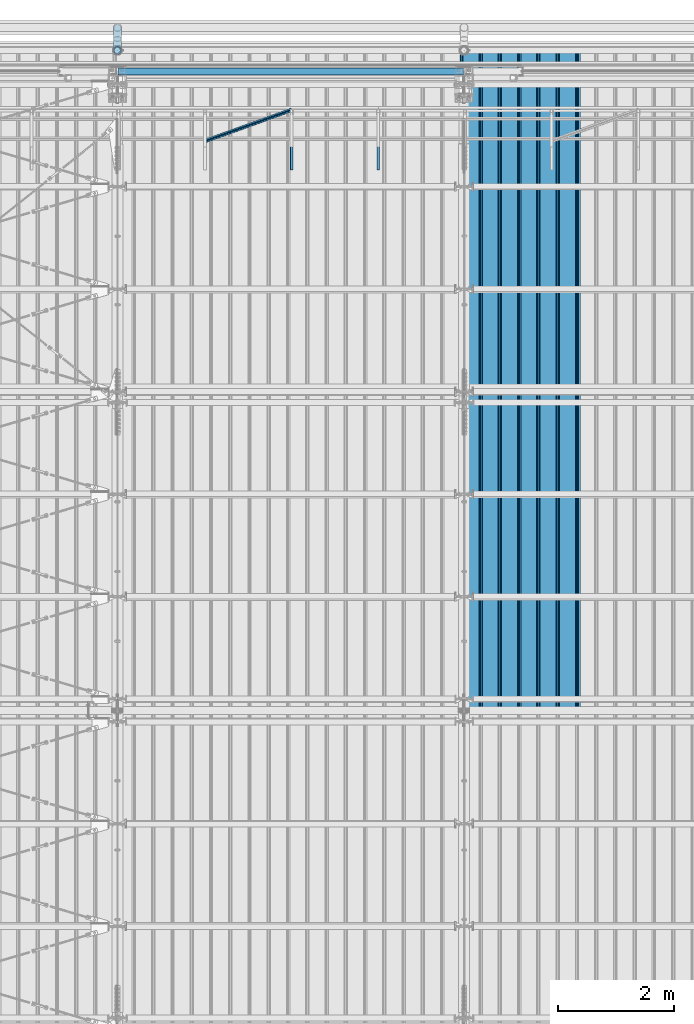
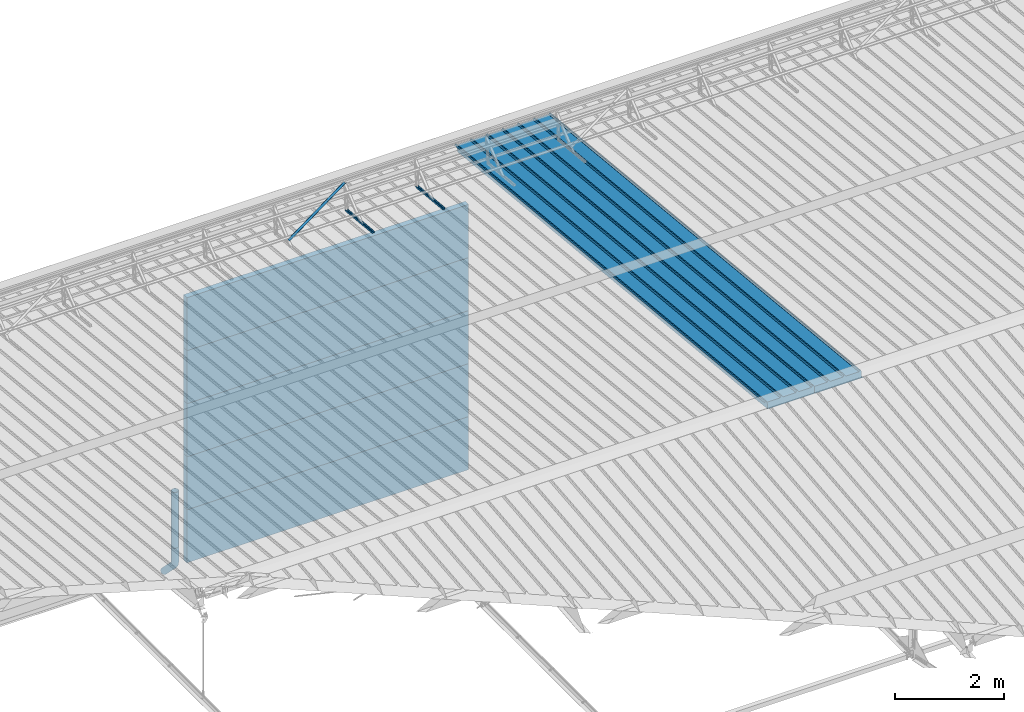
# One storey, part 56 of 709: 12 beams, 12 elements without a shape of their own.
"""IFC4 building model written with IfcOpenShell, lengths in millimetres."""

from ifc_helpers import new_model, entity, si_unit, direction, frame, origin_with_axes, place, context, subcontext, project, spatial, line, indexed_curve, outline, extrude, material, element, aggregate, save


model = new_model("IFC4")

# Units and contexts
model_context = context("Model", 3, precision=0.2, world=origin_with_axes(), true_north=direction((0.0, 1.0)))
body_context = subcontext(model_context, "Body", "Model", "MODEL_VIEW")
ifc_project = project(units=[si_unit("LENGTHUNIT", "METRE", prefix="MILLI"), si_unit("AREAUNIT", "SQUARE_METRE"), si_unit("VOLUMEUNIT", "CUBIC_METRE"), si_unit("MASSUNIT", "GRAM", prefix="KILO"), si_unit("TIMEUNIT", "SECOND"), si_unit("PLANEANGLEUNIT", "RADIAN"), si_unit("SOLIDANGLEUNIT", "STERADIAN"), si_unit("THERMODYNAMICTEMPERATUREUNIT", "DEGREE_CELSIUS"), si_unit("LUMINOUSINTENSITYUNIT", "LUMEN")], contexts=[model_context])

# Site, building, storey
site_placement = place(None, origin_with_axes())
site = spatial("IfcSite", under=ifc_project, at=site_placement, CompositionType="ELEMENT")
building_placement = place(site_placement, origin_with_axes())
building = spatial("IfcBuilding", under=site, at=building_placement, Name="Undefined", CompositionType="ELEMENT")
storey_placement = place(building_placement, origin_with_axes())
storey = spatial("IfcBuildingStorey", under=building, at=storey_placement, Name="Undefined", CompositionType="ELEMENT", Elevation=0.0)

# Assembly, beam
assembly_1_placement = place(storey_placement, frame((17452.44, 11009.10459, 8419.96887), z_axis=(1.0, 0.0, 0.0), x_axis=(0.0, 0.9950371902, -0.099503719)))
assembly_1 = element("IfcElementAssembly", 1, at=assembly_1_placement, inside=storey)
ifc_material_1 = material(Name="Insulation", Category="Insulation")
beam_1_placement = place(assembly_1_placement, origin_with_axes())
beam_1 = element("IfcBeam", 2, at=beam_1_placement, material=ifc_material_1, ObjectType="P-99", context=body_context, shape_type="SolidModel", body=[
    extrude(outline(indexed_curve([(-509.8453, 89.5), (-490.1547, 89.5), (-471.67949, 57.5), (-471.67949, -88.5), (-436.67949, -88.5), (-436.67949, -91.5), (562.55841, -91.5), (562.55841, -89.5), (527.55841, -89.5), (527.55841, 57.5), (510.2379, 88.5), (489.7621, 88.5), (472.44159, 58.5), (196.71923, 58.5), (177.66667, 91.5), (155.66667, 91.5), (136.61411, 58.5), (-136.61411, 58.5), (-155.66667, 91.5), (-177.66667, 91.5), (-196.71923, 58.5), (-469.94744, 58.5), (-489.0, 91.5), (-511.0, 91.5), (-527.16581, 63.5), (-525.43376, 62.5)], segments=[line(1, 2, 3, 4, 5, 6, 7, 8, 9, 10, 11, 12, 13, 14, 15, 16, 17, 18, 19, 20, 21, 22, 23, 24, 25, 26, 1)])), frame((0.0, 0.0, 0.0), z_axis=(-1.0, 0.0, 0.0), x_axis=(0.0, 0.0, 1.0)), (0.0, 0.0, -1.0), 11459.0),
])
aggregate(assembly_1, [beam_1])

assembly_2_placement = place(storey_placement, frame((16452.44, 11009.10459, 8419.96887), z_axis=(1.0, 0.0, 0.0), x_axis=(0.0, 0.9950371902, -0.099503719)))
assembly_2 = element("IfcElementAssembly", 3, at=assembly_2_placement, inside=storey)
beam_2_placement = place(assembly_2_placement, origin_with_axes())
beam_2 = element("IfcBeam", 4, at=beam_2_placement, material=ifc_material_1, ObjectType="P-99", context=body_context, shape_type="SolidModel", body=[
    extrude(outline(indexed_curve([(-509.8453, 89.5), (-490.1547, 89.5), (-471.67949, 57.5), (-471.67949, -88.5), (-436.67949, -88.5), (-436.67949, -91.5), (562.55841, -91.5), (562.55841, -89.5), (527.55841, -89.5), (527.55841, 57.5), (510.2379, 88.5), (489.7621, 88.5), (472.44159, 58.5), (196.71923, 58.5), (177.66667, 91.5), (155.66667, 91.5), (136.61411, 58.5), (-136.61411, 58.5), (-155.66667, 91.5), (-177.66667, 91.5), (-196.71923, 58.5), (-469.94744, 58.5), (-489.0, 91.5), (-511.0, 91.5), (-527.16581, 63.5), (-525.43376, 62.5)], segments=[line(1, 2, 3, 4, 5, 6, 7, 8, 9, 10, 11, 12, 13, 14, 15, 16, 17, 18, 19, 20, 21, 22, 23, 24, 25, 26, 1)])), frame((0.0, 0.0, 0.0), z_axis=(-1.0, 0.0, 0.0), x_axis=(0.0, 0.0, 1.0)), (0.0, 0.0, -1.0), 11459.0),
])
aggregate(assembly_2, [beam_2])

assembly_3_placement = place(storey_placement, frame((14515.0, 21349.29926, 7565.33969), z_axis=(0.0, 0.099503719, 0.9950371902), x_axis=(0.0, -0.9950371902, 0.099503719)))
assembly_3 = element("IfcElementAssembly", 5, at=assembly_3_placement, inside=storey)
ifc_material_2 = material(Name="Steel_Undefined", Category="STEEL")
beam_3_placement = place(assembly_3_placement, origin_with_axes())
beam_3 = element("IfcBeam", 6, at=beam_3_placement, material=ifc_material_2, ObjectType="601", context=body_context, shape_type="SolidModel", body=[
    extrude(outline(indexed_curve([(-20.0, -25.0), (20.0, -25.0), (20.0, -22.5), (-17.5, -22.5), (-17.5, 22.5), (20.0, 22.5), (20.0, 25.0), (-20.0, 25.0)], segments=[line(1, 2, 3, 4, 5, 6, 7, 8, 1)])), frame((0.0, 0.0, 0.0), z_axis=(-1.0, 0.0, 0.0), x_axis=(0.0, 0.0, 1.0)), (0.0, 0.0, -1.0), 1000.0),
])
aggregate(assembly_3, [beam_3])

assembly_4_placement = place(storey_placement, frame((13015.0, 21349.29926, 7565.33969), z_axis=(0.0, 0.099503719, 0.9950371902), x_axis=(0.0, -0.9950371902, 0.099503719)))
assembly_4 = element("IfcElementAssembly", 7, at=assembly_4_placement, inside=storey)
beam_4_placement = place(assembly_4_placement, origin_with_axes())
beam_4 = element("IfcBeam", 8, at=beam_4_placement, material=ifc_material_2, ObjectType="601", context=body_context, shape_type="SolidModel", body=[
    extrude(outline(indexed_curve([(-20.0, -25.0), (20.0, -25.0), (20.0, -22.5), (-17.5, -22.5), (-17.5, 22.5), (20.0, 22.5), (20.0, 25.0), (-20.0, 25.0)], segments=[line(1, 2, 3, 4, 5, 6, 7, 8, 1)])), frame((0.0, 0.0, 0.0), z_axis=(-1.0, 0.0, 0.0), x_axis=(0.0, 0.0, 1.0)), (0.0, 0.0, -1.0), 1000.0),
])
aggregate(assembly_4, [beam_4])

assembly_5_placement = place(storey_placement, frame((13015.0, 21394.34666, 8157.9404), z_axis=(0.0, -0.6332377902, 0.7739572992), x_axis=(-0.9061831398, -0.3272952929, -0.2677870579)))
assembly_5 = element("IfcElementAssembly", 9, at=assembly_5_placement, inside=storey)
beam_5_placement = place(assembly_5_placement, origin_with_axes())
beam_5 = element("IfcBeam", 10, at=beam_5_placement, material=ifc_material_2, ObjectType="605", context=body_context, shape_type="SolidModel", body=[
    extrude(outline(indexed_curve([(-20.0, -25.0), (20.0, -25.0), (20.0, -22.5), (-17.5, -22.5), (-17.5, 22.5), (20.0, 22.5), (20.0, 25.0), (-20.0, 25.0)], segments=[line(1, 2, 3, 4, 5, 6, 7, 8, 1)])), frame((0.0, 0.0, 0.0), z_axis=(-1.0, 0.0, 0.0), x_axis=(0.0, 0.0, 1.0)), (0.0, 0.0, -1.0), 1655.29454),
])
aggregate(assembly_5, [beam_5])

assembly_6_placement = place(storey_placement, frame((10010.0, 22060.0, 895.0), z_axis=(0.0, 0.0, -1.0), x_axis=(1.0, 0.0, 0.0)))
assembly_6 = element("IfcElementAssembly", 11, at=assembly_6_placement, inside=storey)
beam_6_placement = place(assembly_6_placement, origin_with_axes())
beam_6 = element("IfcBeam", 12, at=beam_6_placement, material=ifc_material_1, ObjectType="P-107", context=body_context, shape_type="SolidModel", body=[
    extrude(outline(indexed_curve([(-595.0, -60.0), (595.0, -60.0), (595.0, 60.0), (-595.0, 60.0)], segments=[line(1, 2, 3, 4, 1)])), frame((0.0, 0.0, 0.0), z_axis=(-1.0, 0.0, 0.0), x_axis=(0.0, 0.0, 1.0)), (0.0, 0.0, -1.0), 5980.0),
])
aggregate(assembly_6, [beam_6])

assembly_7_placement = place(storey_placement, frame((10010.0, 22060.0, 2085.0), z_axis=(0.0, 0.0, -1.0), x_axis=(1.0, 0.0, 0.0)))
assembly_7 = element("IfcElementAssembly", 13, at=assembly_7_placement, inside=storey)
beam_7_placement = place(assembly_7_placement, origin_with_axes())
beam_7 = element("IfcBeam", 14, at=beam_7_placement, material=ifc_material_1, ObjectType="P-107", context=body_context, shape_type="SolidModel", body=[
    extrude(outline(indexed_curve([(-595.0, -60.0), (595.0, -60.0), (595.0, 60.0), (-595.0, 60.0)], segments=[line(1, 2, 3, 4, 1)])), frame((0.0, 0.0, 0.0), z_axis=(-1.0, 0.0, 0.0), x_axis=(0.0, 0.0, 1.0)), (0.0, 0.0, -1.0), 5980.0),
])
aggregate(assembly_7, [beam_7])

assembly_8_placement = place(storey_placement, frame((10010.0, 22060.0, 3275.0), z_axis=(0.0, 0.0, -1.0), x_axis=(1.0, 0.0, 0.0)))
assembly_8 = element("IfcElementAssembly", 15, at=assembly_8_placement, inside=storey)
beam_8_placement = place(assembly_8_placement, origin_with_axes())
beam_8 = element("IfcBeam", 16, at=beam_8_placement, material=ifc_material_1, ObjectType="P-107", context=body_context, shape_type="SolidModel", body=[
    extrude(outline(indexed_curve([(-595.0, -60.0), (595.0, -60.0), (595.0, 60.0), (-595.0, 60.0)], segments=[line(1, 2, 3, 4, 1)])), frame((0.0, 0.0, 0.0), z_axis=(-1.0, 0.0, 0.0), x_axis=(0.0, 0.0, 1.0)), (0.0, 0.0, -1.0), 5980.0),
])
aggregate(assembly_8, [beam_8])

assembly_9_placement = place(storey_placement, frame((10010.0, 22060.0, 4465.0), z_axis=(0.0, 0.0, -1.0), x_axis=(1.0, 0.0, 0.0)))
assembly_9 = element("IfcElementAssembly", 17, at=assembly_9_placement, inside=storey)
beam_9_placement = place(assembly_9_placement, origin_with_axes())
beam_9 = element("IfcBeam", 18, at=beam_9_placement, material=ifc_material_1, ObjectType="P-107", context=body_context, shape_type="SolidModel", body=[
    extrude(outline(indexed_curve([(-595.0, -60.0), (595.0, -60.0), (595.0, 60.0), (-595.0, 60.0)], segments=[line(1, 2, 3, 4, 1)])), frame((0.0, 0.0, 0.0), z_axis=(-1.0, 0.0, 0.0), x_axis=(0.0, 0.0, 1.0)), (0.0, 0.0, -1.0), 5980.0),
])
aggregate(assembly_9, [beam_9])

assembly_10_placement = place(storey_placement, frame((10010.0, 22060.0, 5655.0), z_axis=(0.0, 0.0, -1.0), x_axis=(1.0, 0.0, 0.0)))
assembly_10 = element("IfcElementAssembly", 19, at=assembly_10_placement, inside=storey)
beam_10_placement = place(assembly_10_placement, origin_with_axes())
beam_10 = element("IfcBeam", 20, at=beam_10_placement, material=ifc_material_1, ObjectType="P-107", context=body_context, shape_type="SolidModel", body=[
    extrude(outline(indexed_curve([(-595.0, -60.0), (595.0, -60.0), (595.0, 60.0), (-595.0, 60.0)], segments=[line(1, 2, 3, 4, 1)])), frame((0.0, 0.0, 0.0), z_axis=(-1.0, 0.0, 0.0), x_axis=(0.0, 0.0, 1.0)), (0.0, 0.0, -1.0), 5980.0),
])
aggregate(assembly_10, [beam_10])

assembly_11_placement = place(storey_placement, frame((10000.0, 22420.0, 1676.92297), z_axis=(0.0, -1.0, 0.0), x_axis=(0.0, 0.0, -1.0)))
assembly_11 = element("IfcElementAssembly", 21, at=assembly_11_placement, inside=storey)
beam_11_placement = place(assembly_11_placement, origin_with_axes())
beam_11 = element("IfcBeam", 22, at=beam_11_placement, material=ifc_material_2, ObjectType="614", context=body_context, shape_type="SolidModel", body=[
    extrude(outline(indexed_curve([(70.0, 0.0), (69.61653, 7.31699), (68.47033, 14.55382), (66.57396, 21.63119), (63.94818, 28.47157), (60.62178, 35.0), (56.63119, 41.14497), (52.02014, 46.83914), (46.83914, 52.02014), (41.14497, 56.63119), (35.0, 60.62178), (28.47157, 63.94818), (21.63119, 66.57396), (14.55382, 68.47033), (7.31699, 69.61653), (0.0, 70.0), (-7.31699, 69.61653), (-14.55382, 68.47033), (-21.63119, 66.57396), (-28.47157, 63.94818), (-35.0, 60.62178), (-41.14497, 56.63119), (-46.83914, 52.02014), (-52.02014, 46.83914), (-56.63119, 41.14497), (-60.62178, 35.0), (-63.94818, 28.47157), (-66.57396, 21.63119), (-68.47033, 14.55382), (-69.61653, 7.31699), (-70.0, 0.0), (-69.61653, -7.31699), (-68.47033, -14.55382), (-66.57396, -21.63119), (-63.94818, -28.47157), (-60.62178, -35.0), (-56.63119, -41.14497), (-52.02014, -46.83914), (-46.83914, -52.02014), (-41.14497, -56.63119), (-35.0, -60.62178), (-28.47157, -63.94818), (-21.63119, -66.57396), (-14.55382, -68.47033), (-7.31699, -69.61653), (0.0, -70.0), (7.31699, -69.61653), (14.55382, -68.47033), (21.63119, -66.57396), (28.47157, -63.94818), (35.0, -60.62178), (41.14497, -56.63119), (46.83914, -52.02014), (52.02014, -46.83914), (56.63119, -41.14497), (60.62178, -35.0), (63.94818, -28.47157), (66.57396, -21.63119), (68.47033, -14.55382), (69.61653, -7.31699)], segments=[line(1, 2, 3, 4, 5, 6, 7, 8, 9, 10, 11, 12, 13, 14, 15, 16, 17, 18, 19, 20, 21, 22, 23, 24, 25, 26, 27, 28, 29, 30, 31, 32, 33, 34, 35, 36, 37, 38, 39, 40, 41, 42, 43, 44, 45, 46, 47, 48, 49, 50, 51, 52, 53, 54, 55, 56, 57, 58, 59, 60, 1)]), holes=[indexed_curve([(65.0, 0.0), (64.64392, -6.79435), (63.57959, -13.51426), (61.81867, -20.0861), (59.38045, -26.43788), (56.29165, -32.5), (52.5861, -38.20604), (48.30441, -43.49349), (43.49349, -48.30441), (38.20604, -52.5861), (32.5, -56.29165), (26.43788, -59.38045), (20.0861, -61.81867), (13.51426, -63.57959), (6.79435, -64.64392), (0.0, -65.0), (-6.79435, -64.64392), (-13.51426, -63.57959), (-20.0861, -61.81867), (-26.43788, -59.38045), (-32.5, -56.29165), (-38.20604, -52.5861), (-43.49349, -48.30441), (-48.30441, -43.49349), (-52.5861, -38.20604), (-56.29165, -32.5), (-59.38045, -26.43788), (-61.81867, -20.0861), (-63.57959, -13.51426), (-64.64392, -6.79435), (-65.0, 0.0), (-64.64392, 6.79435), (-63.57959, 13.51426), (-61.81867, 20.0861), (-59.38045, 26.43788), (-56.29165, 32.5), (-52.5861, 38.20604), (-48.30441, 43.49349), (-43.49349, 48.30441), (-38.20604, 52.5861), (-32.5, 56.29165), (-26.43788, 59.38045), (-20.0861, 61.81867), (-13.51426, 63.57959), (-6.79435, 64.64392), (0.0, 65.0), (6.79435, 64.64392), (13.51426, 63.57959), (20.0861, 61.81867), (26.43788, 59.38045), (32.5, 56.29165), (38.20604, 52.5861), (43.49349, 48.30441), (48.30441, 43.49349), (52.5861, 38.20604), (56.29165, 32.5), (59.38045, 26.43788), (61.81867, 20.0861), (63.57959, 13.51426), (64.64392, 6.79435)], segments=[line(1, 2, 3, 4, 5, 6, 7, 8, 9, 10, 11, 12, 13, 14, 15, 16, 17, 18, 19, 20, 21, 22, 23, 24, 25, 26, 27, 28, 29, 30, 31, 32, 33, 34, 35, 36, 37, 38, 39, 40, 41, 42, 43, 44, 45, 46, 47, 48, 49, 50, 51, 52, 53, 54, 55, 56, 57, 58, 59, 60, 1)])]), frame((0.0, 0.0, 0.0), z_axis=(-1.0, 0.0, 0.0), x_axis=(0.0, 0.0, 1.0)), (0.0, 0.0, -1.0), 1250.0),
])
aggregate(assembly_11, [beam_11])

assembly_12_placement = place(storey_placement, frame((10000.0, 22420.0, 526.92297), z_axis=(1.0, 0.0, 0.0), x_axis=(0.0, 0.0, -1.0)))
assembly_12 = element("IfcElementAssembly", 23, at=assembly_12_placement, inside=storey)
beam_12_placement = place(assembly_12_placement, origin_with_axes())
beam_12 = element("IfcBeam", 24, at=beam_12_placement, material=ifc_material_2, ObjectType="617", context=body_context, shape_type="SolidModel", body=[
    entity("IfcSweptDiskSolid", entity("IfcIndexedPolyCurve", entity("IfcCartesianPointList3D", [[0.0, 0.0, 0.0], [448.2233, 0.0, 0.0], [496.05873, 9.51506, 0.0], [536.61165, 36.61165, 0.0], [900.0, 400.0, 0.0]]), [entity("IfcLineIndex", [1, 2]), entity("IfcArcIndex", [2, 3, 4]), entity("IfcLineIndex", [4, 5])]), 70.0, 65.0),
])
aggregate(assembly_12, [beam_12])

save(model, "model.ifc")
